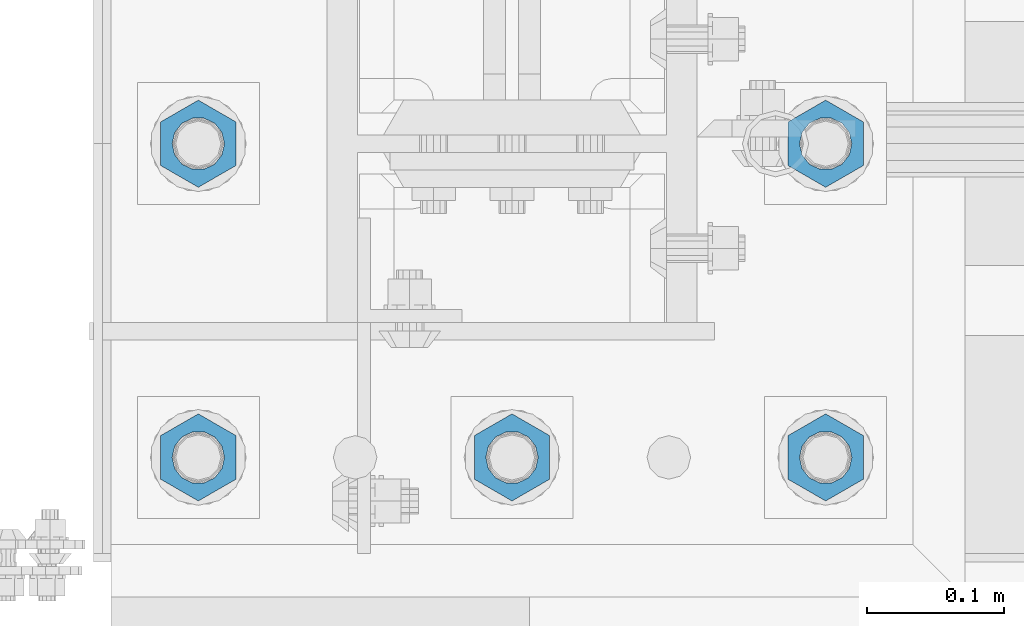
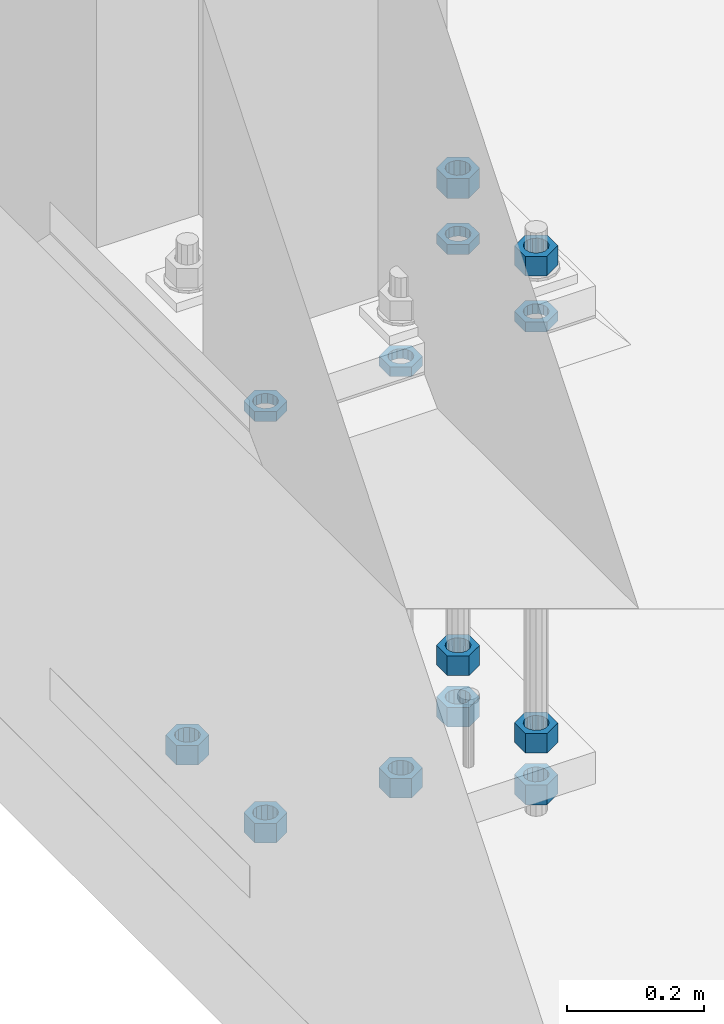
# One storey, part 1381 of 1876: 13 beams, 1 element without a shape of its own.
"""IFC2X3 building model written with IfcOpenShell, lengths in millimetres."""

from ifc_helpers import new_model, si_unit, frame, origin_with_axes, place, context, subcontext, project, spatial, faceted_brep, material, type_object, element, aggregate, save


model = new_model("IFC2X3")

# Units and contexts
model_context = context("Model", 3, precision=1e-05, world=origin_with_axes())
body_context = subcontext(model_context, "Body", "Model", "MODEL_VIEW")
ifc_project = project(units=[si_unit("LENGTHUNIT", "METRE", prefix="MILLI"), si_unit("AREAUNIT", "SQUARE_METRE"), si_unit("VOLUMEUNIT", "CUBIC_METRE"), si_unit("MASSUNIT", "GRAM", prefix="KILO"), si_unit("TIMEUNIT", "SECOND"), si_unit("PLANEANGLEUNIT", "RADIAN"), si_unit("SOLIDANGLEUNIT", "STERADIAN"), si_unit("THERMODYNAMICTEMPERATUREUNIT", "DEGREE_CELSIUS"), si_unit("LUMINOUSINTENSITYUNIT", "LUMEN")], contexts=[model_context])

# Site, building, storey
site_placement = place(None, origin_with_axes())
site = spatial("IfcSite", under=ifc_project, at=site_placement, CompositionType="ELEMENT")
building_placement = place(site_placement, origin_with_axes())
building = spatial("IfcBuilding", under=site, at=building_placement, Name="Undefined", CompositionType="ELEMENT")
storey_placement = place(building_placement, origin_with_axes())
storey = spatial("IfcBuildingStorey", under=building, at=storey_placement, Name="Undefined", CompositionType="ELEMENT", Elevation=0.0)

# Assembly, beams
assembly_placement = place(storey_placement, origin_with_axes())
assembly = element("IfcElementAssembly", 1, at=assembly_placement, inside=storey, Name="TEMPLATE", AssemblyPlace="NOTDEFINED", PredefinedType="RIGID_FRAME")
ifc_material = material(Name="STEEL/A563")
beam_type_1 = type_object("IfcBeamType", Name="1-3/8_DIA. HALF_NUT", PredefinedType="NOTDEFINED")
beam_1_placement = place(assembly_placement, frame((-228.6, -7340.6, 33.3375), z_axis=(1.0, 0.0, 0.0), x_axis=(0.0, 0.0, -1.0)))
beam_1 = element("IfcBeam", 2, at=beam_1_placement, type_object=beam_type_1, material=ifc_material, Name="NUT", ObjectType="1-3/8_DIA. HALF_NUT", context=body_context, shape_type="Brep", body=[
    faceted_brep([(0.0, -31.75, 0.0), (0.0, -15.8800001144409, -27.5), (17.4625, -15.8800001144409, -27.5), (17.4625, -31.75, 0.0), (0.0, 15.8800001144409, -27.5), (17.4625, 15.8800001144409, -27.5), (0.0, 31.75, 0.0), (17.4625, 31.75, 0.0), (0.0, 15.8800001144409, 27.5), (17.4625, 15.8800001144409, 27.5), (0.0, -15.8800001144409, 27.5), (17.4625, -15.8800001144409, 27.5), (0.0, 0.0, 19.0499999999993), (0.0, 8.2654848991624, 17.1634562461559), (17.4625, 8.2654848991624, 17.1634562461559), (17.4625, 0.0, 19.0499992370605), (0.0, 14.8938891445259, 11.8774802497237), (17.4625, 14.8938891445259, 11.8774802497237), (0.0, 18.5723759832526, 4.2390236220981), (17.4625, 18.5723759832526, 4.2390236220981), (0.0, 18.5723759832526, -4.2390236220981), (17.4625, 18.5723759832526, -4.2390236220981), (0.0, 14.8938891445259, -11.8774802497237), (17.4625, 14.8938891445259, -11.8774802497237), (0.0, 8.2654848991624, -17.1634562461568), (17.4625, 8.2654848991624, -17.1634562461568), (0.0, 0.0, -19.05), (17.4625, 0.0, -19.0499992370605), (0.0, -8.2654848991624, -17.1634562461559), (17.4625, -8.2654848991624, -17.1634562461559), (0.0, -14.8938891445259, -11.8774802497237), (17.4625, -14.8938891445259, -11.8774802497237), (0.0, -18.5723759832526, -4.2390236220981), (17.4625, -18.5723759832526, -4.2390236220981), (0.0, -18.5723759832526, 4.2390236220981), (17.4625, -18.5723759832526, 4.2390236220981), (0.0, -14.8938891445259, 11.8774802497237), (17.4625, -14.8938891445259, 11.8774802497237), (0.0, -8.2654848991624, 17.1634562461568), (17.4625, -8.2654848991624, 17.1634562461568)], [[[0, 1, 2, 3]], [[1, 4, 5, 2]], [[4, 6, 7, 5]], [[6, 8, 9, 7]], [[8, 10, 11, 9]], [[10, 0, 3, 11]], [[12, 13, 14, 15]], [[13, 16, 17, 14]], [[16, 18, 19, 17]], [[18, 20, 21, 19]], [[20, 22, 23, 21]], [[22, 24, 25, 23]], [[24, 26, 27, 25]], [[26, 28, 29, 27]], [[28, 30, 31, 29]], [[30, 32, 33, 31]], [[32, 34, 35, 33]], [[34, 36, 37, 35]], [[36, 38, 39, 37]], [[38, 12, 15, 39]], [[5, 7, 9, 11, 3, 2], [17, 19, 21, 23, 25, 27, 29, 31, 33, 35, 37, 39, 15, 14]], [[10, 8, 6, 4, 1, 0], [38, 36, 34, 32, 30, 28, 26, 24, 22, 20, 18, 16, 13, 12]]]),
])
beam_2_placement = place(assembly_placement, frame((228.6, -7112.0, 33.3375), z_axis=(1.0, 0.0, 0.0), x_axis=(0.0, 0.0, -1.0)))
beam_2 = element("IfcBeam", 3, at=beam_2_placement, type_object=beam_type_1, material=ifc_material, Name="NUT", ObjectType="1-3/8_DIA. HALF_NUT", context=body_context, shape_type="Brep", body=[
    faceted_brep([(0.0, -31.75, 0.0), (0.0, -15.8800001144409, -27.5), (17.4625, -15.8800001144409, -27.5), (17.4625, -31.75, 0.0), (0.0, 15.8800001144409, -27.5), (17.4625, 15.8800001144409, -27.5), (0.0, 31.75, 0.0), (17.4625, 31.75, 0.0), (0.0, 15.8800001144409, 27.5), (17.4625, 15.8800001144409, 27.5), (0.0, -15.8800001144409, 27.5), (17.4625, -15.8800001144409, 27.5), (0.0, 0.0, 19.0499999999993), (0.0, 8.2654848991624, 17.1634562461559), (17.4625, 8.2654848991624, 17.1634562461559), (17.4625, 0.0, 19.0499992370605), (0.0, 14.8938891445259, 11.8774802497237), (17.4625, 14.8938891445259, 11.8774802497237), (0.0, 18.5723759832526, 4.2390236220981), (17.4625, 18.5723759832526, 4.2390236220981), (0.0, 18.5723759832526, -4.2390236220981), (17.4625, 18.5723759832526, -4.2390236220981), (0.0, 14.8938891445259, -11.8774802497237), (17.4625, 14.8938891445259, -11.8774802497237), (0.0, 8.2654848991624, -17.1634562461568), (17.4625, 8.2654848991624, -17.1634562461568), (0.0, 0.0, -19.05), (17.4625, 0.0, -19.0499992370605), (0.0, -8.2654848991624, -17.1634562461559), (17.4625, -8.2654848991624, -17.1634562461559), (0.0, -14.8938891445259, -11.8774802497237), (17.4625, -14.8938891445259, -11.8774802497237), (0.0, -18.5723759832526, -4.2390236220981), (17.4625, -18.5723759832526, -4.2390236220981), (0.0, -18.5723759832526, 4.2390236220981), (17.4625, -18.5723759832526, 4.2390236220981), (0.0, -14.8938891445259, 11.8774802497237), (17.4625, -14.8938891445259, 11.8774802497237), (0.0, -8.2654848991624, 17.1634562461568), (17.4625, -8.2654848991624, 17.1634562461568)], [[[0, 1, 2, 3]], [[1, 4, 5, 2]], [[4, 6, 7, 5]], [[6, 8, 9, 7]], [[8, 10, 11, 9]], [[10, 0, 3, 11]], [[12, 13, 14, 15]], [[13, 16, 17, 14]], [[16, 18, 19, 17]], [[18, 20, 21, 19]], [[20, 22, 23, 21]], [[22, 24, 25, 23]], [[24, 26, 27, 25]], [[26, 28, 29, 27]], [[28, 30, 31, 29]], [[30, 32, 33, 31]], [[32, 34, 35, 33]], [[34, 36, 37, 35]], [[36, 38, 39, 37]], [[38, 12, 15, 39]], [[5, 7, 9, 11, 3, 2], [17, 19, 21, 23, 25, 27, 29, 31, 33, 35, 37, 39, 15, 14]], [[10, 8, 6, 4, 1, 0], [38, 36, 34, 32, 30, 28, 26, 24, 22, 20, 18, 16, 13, 12]]]),
])
beam_3_placement = place(assembly_placement, frame((228.6, -7340.6, 33.3375), z_axis=(1.0, 0.0, 0.0), x_axis=(0.0, 0.0, -1.0)))
beam_3 = element("IfcBeam", 4, at=beam_3_placement, type_object=beam_type_1, material=ifc_material, Name="NUT", ObjectType="1-3/8_DIA. HALF_NUT", context=body_context, shape_type="Brep", body=[
    faceted_brep([(0.0, -31.75, 0.0), (0.0, -15.8800001144409, -27.5), (17.4625, -15.8800001144409, -27.5), (17.4625, -31.75, 0.0), (0.0, 15.8800001144409, -27.5), (17.4625, 15.8800001144409, -27.5), (0.0, 31.75, 0.0), (17.4625, 31.75, 0.0), (0.0, 15.8800001144409, 27.5), (17.4625, 15.8800001144409, 27.5), (0.0, -15.8800001144409, 27.5), (17.4625, -15.8800001144409, 27.5), (0.0, 0.0, 19.0499999999993), (0.0, 8.2654848991624, 17.1634562461559), (17.4625, 8.2654848991624, 17.1634562461559), (17.4625, 0.0, 19.0499992370605), (0.0, 14.8938891445259, 11.8774802497237), (17.4625, 14.8938891445259, 11.8774802497237), (0.0, 18.5723759832526, 4.2390236220981), (17.4625, 18.5723759832526, 4.2390236220981), (0.0, 18.5723759832526, -4.2390236220981), (17.4625, 18.5723759832526, -4.2390236220981), (0.0, 14.8938891445259, -11.8774802497237), (17.4625, 14.8938891445259, -11.8774802497237), (0.0, 8.2654848991624, -17.1634562461568), (17.4625, 8.2654848991624, -17.1634562461568), (0.0, 0.0, -19.05), (17.4625, 0.0, -19.0499992370605), (0.0, -8.2654848991624, -17.1634562461559), (17.4625, -8.2654848991624, -17.1634562461559), (0.0, -14.8938891445259, -11.8774802497237), (17.4625, -14.8938891445259, -11.8774802497237), (0.0, -18.5723759832526, -4.2390236220981), (17.4625, -18.5723759832526, -4.2390236220981), (0.0, -18.5723759832526, 4.2390236220981), (17.4625, -18.5723759832526, 4.2390236220981), (0.0, -14.8938891445259, 11.8774802497237), (17.4625, -14.8938891445259, 11.8774802497237), (0.0, -8.2654848991624, 17.1634562461568), (17.4625, -8.2654848991624, 17.1634562461568)], [[[0, 1, 2, 3]], [[1, 4, 5, 2]], [[4, 6, 7, 5]], [[6, 8, 9, 7]], [[8, 10, 11, 9]], [[10, 0, 3, 11]], [[12, 13, 14, 15]], [[13, 16, 17, 14]], [[16, 18, 19, 17]], [[18, 20, 21, 19]], [[20, 22, 23, 21]], [[22, 24, 25, 23]], [[24, 26, 27, 25]], [[26, 28, 29, 27]], [[28, 30, 31, 29]], [[30, 32, 33, 31]], [[32, 34, 35, 33]], [[34, 36, 37, 35]], [[36, 38, 39, 37]], [[38, 12, 15, 39]], [[5, 7, 9, 11, 3, 2], [17, 19, 21, 23, 25, 27, 29, 31, 33, 35, 37, 39, 15, 14]], [[10, 8, 6, 4, 1, 0], [38, 36, 34, 32, 30, 28, 26, 24, 22, 20, 18, 16, 13, 12]]]),
])
beam_4_placement = place(assembly_placement, frame((0.0, -7340.6, 33.3375), z_axis=(1.0, 0.0, 0.0), x_axis=(0.0, 0.0, -1.0)))
beam_4 = element("IfcBeam", 5, at=beam_4_placement, type_object=beam_type_1, material=ifc_material, Name="NUT", ObjectType="1-3/8_DIA. HALF_NUT", context=body_context, shape_type="Brep", body=[
    faceted_brep([(0.0, -31.75, 0.0), (0.0, -15.8800001144409, -27.5), (17.4625, -15.8800001144409, -27.5), (17.4625, -31.75, 0.0), (0.0, 15.8800001144409, -27.5), (17.4625, 15.8800001144409, -27.5), (0.0, 31.75, 0.0), (17.4625, 31.75, 0.0), (0.0, 15.8800001144409, 27.5), (17.4625, 15.8800001144409, 27.5), (0.0, -15.8800001144409, 27.5), (17.4625, -15.8800001144409, 27.5), (0.0, 0.0, 19.0499999999993), (0.0, 8.2654848991624, 17.1634562461559), (17.4625, 8.2654848991624, 17.1634562461559), (17.4625, 0.0, 19.0499992370605), (0.0, 14.8938891445259, 11.8774802497237), (17.4625, 14.8938891445259, 11.8774802497237), (0.0, 18.5723759832526, 4.2390236220981), (17.4625, 18.5723759832526, 4.2390236220981), (0.0, 18.5723759832526, -4.2390236220981), (17.4625, 18.5723759832526, -4.2390236220981), (0.0, 14.8938891445259, -11.8774802497237), (17.4625, 14.8938891445259, -11.8774802497237), (0.0, 8.2654848991624, -17.1634562461568), (17.4625, 8.2654848991624, -17.1634562461568), (0.0, 0.0, -19.05), (17.4625, 0.0, -19.0499992370605), (0.0, -8.2654848991624, -17.1634562461559), (17.4625, -8.2654848991624, -17.1634562461559), (0.0, -14.8938891445259, -11.8774802497237), (17.4625, -14.8938891445259, -11.8774802497237), (0.0, -18.5723759832526, -4.2390236220981), (17.4625, -18.5723759832526, -4.2390236220981), (0.0, -18.5723759832526, 4.2390236220981), (17.4625, -18.5723759832526, 4.2390236220981), (0.0, -14.8938891445259, 11.8774802497237), (17.4625, -14.8938891445259, 11.8774802497237), (0.0, -8.2654848991624, 17.1634562461568), (17.4625, -8.2654848991624, 17.1634562461568)], [[[0, 1, 2, 3]], [[1, 4, 5, 2]], [[4, 6, 7, 5]], [[6, 8, 9, 7]], [[8, 10, 11, 9]], [[10, 0, 3, 11]], [[12, 13, 14, 15]], [[13, 16, 17, 14]], [[16, 18, 19, 17]], [[18, 20, 21, 19]], [[20, 22, 23, 21]], [[22, 24, 25, 23]], [[24, 26, 27, 25]], [[26, 28, 29, 27]], [[28, 30, 31, 29]], [[30, 32, 33, 31]], [[32, 34, 35, 33]], [[34, 36, 37, 35]], [[36, 38, 39, 37]], [[38, 12, 15, 39]], [[5, 7, 9, 11, 3, 2], [17, 19, 21, 23, 25, 27, 29, 31, 33, 35, 37, 39, 15, 14]], [[10, 8, 6, 4, 1, 0], [38, 36, 34, 32, 30, 28, 26, 24, 22, 20, 18, 16, 13, 12]]]),
])
beam_type_2 = type_object("IfcBeamType", Name="1-3/8_HEAVY_HEX_NUT", PredefinedType="NOTDEFINED")
beam_5_placement = place(assembly_placement, frame((228.600012207031, -7340.6, -701.674998474121), z_axis=(1.0, 0.0, 0.0), x_axis=(0.0, 0.0, -1.0)))
beam_5 = element("IfcBeam", 6, at=beam_5_placement, type_object=beam_type_2, material=ifc_material, Name="NUT", ObjectType="1-3/8_HEAVY_HEX_NUT", context=body_context, shape_type="Brep", body=[
    faceted_brep([(0.0, -31.75, 0.0), (0.0, -15.8800001144409, -27.5), (34.925, -15.8800001144409, -27.5), (34.925, -31.75, 0.0), (0.0, 15.8800001144409, -27.5), (34.925, 15.8800001144409, -27.5), (0.0, 31.75, 0.0), (34.925, 31.75, 0.0), (0.0, 15.8800001144409, 27.5), (34.925, 15.8800001144409, 27.5), (0.0, -15.8800001144409, 27.5), (34.925, -15.8800001144409, 27.5), (0.0, 0.0, 19.0499999999993), (0.0, 8.2654848991624, 17.1634562461559), (34.925, 8.26548489916252, 17.163456246155), (34.925, 0.0, 19.0499992370605), (0.0, 14.8938891445259, 11.8774802497237), (34.925, 14.8938891445259, 11.8774802497246), (0.0, 18.5723759832526, 4.2390236220981), (34.925, 18.5723759832528, 4.23902362209628), (0.0, 18.5723759832526, -4.2390236220981), (34.925, 18.5723759832528, -4.23902362209628), (0.0, 14.8938891445259, -11.8774802497237), (34.925, 14.8938891445259, -11.8774802497246), (0.0, 8.2654848991624, -17.1634562461568), (34.925, 8.26548489916252, -17.163456246155), (0.0, 0.0, -19.05), (34.925, 0.0, -19.0499992370605), (0.0, -8.2654848991624, -17.1634562461559), (34.925, -8.26548489916252, -17.163456246155), (0.0, -14.8938891445259, -11.8774802497237), (34.925, -14.8938891445259, -11.8774802497246), (0.0, -18.5723759832526, -4.2390236220981), (34.925, -18.5723759832528, -4.23902362209628), (0.0, -18.5723759832526, 4.2390236220981), (34.925, -18.5723759832528, 4.23902362209628), (0.0, -14.8938891445259, 11.8774802497237), (34.925, -14.8938891445259, 11.8774802497246), (0.0, -8.2654848991624, 17.1634562461568), (34.925, -8.26548489916252, 17.163456246155)], [[[0, 1, 2, 3]], [[1, 4, 5, 2]], [[4, 6, 7, 5]], [[6, 8, 9, 7]], [[8, 10, 11, 9]], [[10, 0, 3, 11]], [[12, 13, 14, 15]], [[13, 16, 17, 14]], [[16, 18, 19, 17]], [[18, 20, 21, 19]], [[20, 22, 23, 21]], [[22, 24, 25, 23]], [[24, 26, 27, 25]], [[26, 28, 29, 27]], [[28, 30, 31, 29]], [[30, 32, 33, 31]], [[32, 34, 35, 33]], [[34, 36, 37, 35]], [[36, 38, 39, 37]], [[38, 12, 15, 39]], [[5, 7, 9, 11, 3, 2], [17, 19, 21, 23, 25, 27, 29, 31, 33, 35, 37, 39, 15, 14]], [[10, 8, 6, 4, 1, 0], [38, 36, 34, 32, 30, 28, 26, 24, 22, 20, 18, 16, 13, 12]]]),
])
beam_6_placement = place(assembly_placement, frame((228.600012207031, -7112.0, -701.674998474121), z_axis=(1.0, 0.0, 0.0), x_axis=(0.0, 0.0, -1.0)))
beam_6 = element("IfcBeam", 7, at=beam_6_placement, type_object=beam_type_2, material=ifc_material, Name="NUT", ObjectType="1-3/8_HEAVY_HEX_NUT", context=body_context, shape_type="Brep", body=[
    faceted_brep([(0.0, -31.75, 0.0), (0.0, -15.8800001144409, -27.5), (34.925, -15.8800001144409, -27.5), (34.925, -31.75, 0.0), (0.0, 15.8800001144409, -27.5), (34.925, 15.8800001144409, -27.5), (0.0, 31.75, 0.0), (34.925, 31.75, 0.0), (0.0, 15.8800001144409, 27.5), (34.925, 15.8800001144409, 27.5), (0.0, -15.8800001144409, 27.5), (34.925, -15.8800001144409, 27.5), (0.0, 0.0, 19.0499999999993), (0.0, 8.2654848991624, 17.1634562461559), (34.925, 8.26548489916252, 17.163456246155), (34.925, 0.0, 19.0499992370605), (0.0, 14.8938891445259, 11.8774802497237), (34.925, 14.8938891445259, 11.8774802497246), (0.0, 18.5723759832526, 4.2390236220981), (34.925, 18.5723759832528, 4.23902362209628), (0.0, 18.5723759832526, -4.2390236220981), (34.925, 18.5723759832528, -4.23902362209628), (0.0, 14.8938891445259, -11.8774802497237), (34.925, 14.8938891445259, -11.8774802497246), (0.0, 8.2654848991624, -17.1634562461568), (34.925, 8.26548489916252, -17.163456246155), (0.0, 0.0, -19.05), (34.925, 0.0, -19.0499992370605), (0.0, -8.2654848991624, -17.1634562461559), (34.925, -8.26548489916252, -17.163456246155), (0.0, -14.8938891445259, -11.8774802497237), (34.925, -14.8938891445259, -11.8774802497246), (0.0, -18.5723759832526, -4.2390236220981), (34.925, -18.5723759832528, -4.23902362209628), (0.0, -18.5723759832526, 4.2390236220981), (34.925, -18.5723759832528, 4.23902362209628), (0.0, -14.8938891445259, 11.8774802497237), (34.925, -14.8938891445259, 11.8774802497246), (0.0, -8.2654848991624, 17.1634562461568), (34.925, -8.26548489916252, 17.163456246155)], [[[0, 1, 2, 3]], [[1, 4, 5, 2]], [[4, 6, 7, 5]], [[6, 8, 9, 7]], [[8, 10, 11, 9]], [[10, 0, 3, 11]], [[12, 13, 14, 15]], [[13, 16, 17, 14]], [[16, 18, 19, 17]], [[18, 20, 21, 19]], [[20, 22, 23, 21]], [[22, 24, 25, 23]], [[24, 26, 27, 25]], [[26, 28, 29, 27]], [[28, 30, 31, 29]], [[30, 32, 33, 31]], [[32, 34, 35, 33]], [[34, 36, 37, 35]], [[36, 38, 39, 37]], [[38, 12, 15, 39]], [[5, 7, 9, 11, 3, 2], [17, 19, 21, 23, 25, 27, 29, 31, 33, 35, 37, 39, 15, 14]], [[10, 8, 6, 4, 1, 0], [38, 36, 34, 32, 30, 28, 26, 24, 22, 20, 18, 16, 13, 12]]]),
])
beam_7_placement = place(assembly_placement, frame((1.22070313182121e-05, -7340.6, -701.674998474121), z_axis=(1.0, 0.0, 0.0), x_axis=(0.0, 0.0, -1.0)))
beam_7 = element("IfcBeam", 8, at=beam_7_placement, type_object=beam_type_2, material=ifc_material, Name="NUT", ObjectType="1-3/8_HEAVY_HEX_NUT", context=body_context, shape_type="Brep", body=[
    faceted_brep([(0.0, -31.75, 0.0), (0.0, -15.8800001144409, -27.5), (34.925, -15.8800001144409, -27.5), (34.925, -31.75, 0.0), (0.0, 15.8800001144409, -27.5), (34.925, 15.8800001144409, -27.5), (0.0, 31.75, 0.0), (34.925, 31.75, 0.0), (0.0, 15.8800001144409, 27.5), (34.925, 15.8800001144409, 27.5), (0.0, -15.8800001144409, 27.5), (34.925, -15.8800001144409, 27.5), (0.0, 0.0, 19.0499999999993), (0.0, 8.2654848991624, 17.1634562461559), (34.925, 8.26548489916252, 17.163456246155), (34.925, 0.0, 19.0499992370605), (0.0, 14.8938891445259, 11.8774802497237), (34.925, 14.8938891445259, 11.8774802497246), (0.0, 18.5723759832526, 4.2390236220981), (34.925, 18.5723759832528, 4.23902362209628), (0.0, 18.5723759832526, -4.2390236220981), (34.925, 18.5723759832528, -4.23902362209628), (0.0, 14.8938891445259, -11.8774802497237), (34.925, 14.8938891445259, -11.8774802497246), (0.0, 8.2654848991624, -17.1634562461568), (34.925, 8.26548489916252, -17.163456246155), (0.0, 0.0, -19.05), (34.925, 0.0, -19.0499992370605), (0.0, -8.2654848991624, -17.1634562461559), (34.925, -8.26548489916252, -17.163456246155), (0.0, -14.8938891445259, -11.8774802497237), (34.925, -14.8938891445259, -11.8774802497246), (0.0, -18.5723759832526, -4.2390236220981), (34.925, -18.5723759832528, -4.23902362209628), (0.0, -18.5723759832526, 4.2390236220981), (34.925, -18.5723759832528, 4.23902362209628), (0.0, -14.8938891445259, 11.8774802497237), (34.925, -14.8938891445259, 11.8774802497246), (0.0, -8.2654848991624, 17.1634562461568), (34.925, -8.26548489916252, 17.163456246155)], [[[0, 1, 2, 3]], [[1, 4, 5, 2]], [[4, 6, 7, 5]], [[6, 8, 9, 7]], [[8, 10, 11, 9]], [[10, 0, 3, 11]], [[12, 13, 14, 15]], [[13, 16, 17, 14]], [[16, 18, 19, 17]], [[18, 20, 21, 19]], [[20, 22, 23, 21]], [[22, 24, 25, 23]], [[24, 26, 27, 25]], [[26, 28, 29, 27]], [[28, 30, 31, 29]], [[30, 32, 33, 31]], [[32, 34, 35, 33]], [[34, 36, 37, 35]], [[36, 38, 39, 37]], [[38, 12, 15, 39]], [[5, 7, 9, 11, 3, 2], [17, 19, 21, 23, 25, 27, 29, 31, 33, 35, 37, 39, 15, 14]], [[10, 8, 6, 4, 1, 0], [38, 36, 34, 32, 30, 28, 26, 24, 22, 20, 18, 16, 13, 12]]]),
])
beam_8_placement = place(assembly_placement, frame((-228.599987792969, -7340.6, -701.674998474121), z_axis=(1.0, 0.0, 0.0), x_axis=(0.0, 0.0, -1.0)))
beam_8 = element("IfcBeam", 9, at=beam_8_placement, type_object=beam_type_2, material=ifc_material, Name="NUT", ObjectType="1-3/8_HEAVY_HEX_NUT", context=body_context, shape_type="Brep", body=[
    faceted_brep([(0.0, -31.75, 0.0), (0.0, -15.8800001144409, -27.5), (34.925, -15.8800001144409, -27.5), (34.925, -31.75, 0.0), (0.0, 15.8800001144409, -27.5), (34.925, 15.8800001144409, -27.5), (0.0, 31.75, 0.0), (34.925, 31.75, 0.0), (0.0, 15.8800001144409, 27.5), (34.925, 15.8800001144409, 27.5), (0.0, -15.8800001144409, 27.5), (34.925, -15.8800001144409, 27.5), (0.0, 0.0, 19.0499999999993), (0.0, 8.2654848991624, 17.1634562461559), (34.925, 8.26548489916252, 17.163456246155), (34.925, 0.0, 19.0499992370605), (0.0, 14.8938891445259, 11.8774802497237), (34.925, 14.8938891445259, 11.8774802497246), (0.0, 18.5723759832526, 4.2390236220981), (34.925, 18.5723759832528, 4.23902362209628), (0.0, 18.5723759832526, -4.2390236220981), (34.925, 18.5723759832528, -4.23902362209628), (0.0, 14.8938891445259, -11.8774802497237), (34.925, 14.8938891445259, -11.8774802497246), (0.0, 8.2654848991624, -17.1634562461568), (34.925, 8.26548489916252, -17.163456246155), (0.0, 0.0, -19.05), (34.925, 0.0, -19.0499992370605), (0.0, -8.2654848991624, -17.1634562461559), (34.925, -8.26548489916252, -17.163456246155), (0.0, -14.8938891445259, -11.8774802497237), (34.925, -14.8938891445259, -11.8774802497246), (0.0, -18.5723759832526, -4.2390236220981), (34.925, -18.5723759832528, -4.23902362209628), (0.0, -18.5723759832526, 4.2390236220981), (34.925, -18.5723759832528, 4.23902362209628), (0.0, -14.8938891445259, 11.8774802497237), (34.925, -14.8938891445259, 11.8774802497246), (0.0, -8.2654848991624, 17.1634562461568), (34.925, -8.26548489916252, 17.163456246155)], [[[0, 1, 2, 3]], [[1, 4, 5, 2]], [[4, 6, 7, 5]], [[6, 8, 9, 7]], [[8, 10, 11, 9]], [[10, 0, 3, 11]], [[12, 13, 14, 15]], [[13, 16, 17, 14]], [[16, 18, 19, 17]], [[18, 20, 21, 19]], [[20, 22, 23, 21]], [[22, 24, 25, 23]], [[24, 26, 27, 25]], [[26, 28, 29, 27]], [[28, 30, 31, 29]], [[30, 32, 33, 31]], [[32, 34, 35, 33]], [[34, 36, 37, 35]], [[36, 38, 39, 37]], [[38, 12, 15, 39]], [[5, 7, 9, 11, 3, 2], [17, 19, 21, 23, 25, 27, 29, 31, 33, 35, 37, 39, 15, 14]], [[10, 8, 6, 4, 1, 0], [38, 36, 34, 32, 30, 28, 26, 24, 22, 20, 18, 16, 13, 12]]]),
])
beam_9_placement = place(assembly_placement, frame((-228.599987792969, -7112.0, -701.674998474121), z_axis=(1.0, 0.0, 0.0), x_axis=(0.0, 0.0, -1.0)))
beam_9 = element("IfcBeam", 10, at=beam_9_placement, type_object=beam_type_2, material=ifc_material, Name="NUT", ObjectType="1-3/8_HEAVY_HEX_NUT", context=body_context, shape_type="Brep", body=[
    faceted_brep([(0.0, -31.75, 0.0), (0.0, -15.8800001144409, -27.5), (34.925, -15.8800001144409, -27.5), (34.925, -31.75, 0.0), (0.0, 15.8800001144409, -27.5), (34.925, 15.8800001144409, -27.5), (0.0, 31.75, 0.0), (34.925, 31.75, 0.0), (0.0, 15.8800001144409, 27.5), (34.925, 15.8800001144409, 27.5), (0.0, -15.8800001144409, 27.5), (34.925, -15.8800001144409, 27.5), (0.0, 0.0, 19.0499999999993), (0.0, 8.2654848991624, 17.1634562461559), (34.925, 8.26548489916252, 17.163456246155), (34.925, 0.0, 19.0499992370605), (0.0, 14.8938891445259, 11.8774802497237), (34.925, 14.8938891445259, 11.8774802497246), (0.0, 18.5723759832526, 4.2390236220981), (34.925, 18.5723759832528, 4.23902362209628), (0.0, 18.5723759832526, -4.2390236220981), (34.925, 18.5723759832528, -4.23902362209628), (0.0, 14.8938891445259, -11.8774802497237), (34.925, 14.8938891445259, -11.8774802497246), (0.0, 8.2654848991624, -17.1634562461568), (34.925, 8.26548489916252, -17.163456246155), (0.0, 0.0, -19.05), (34.925, 0.0, -19.0499992370605), (0.0, -8.2654848991624, -17.1634562461559), (34.925, -8.26548489916252, -17.163456246155), (0.0, -14.8938891445259, -11.8774802497237), (34.925, -14.8938891445259, -11.8774802497246), (0.0, -18.5723759832526, -4.2390236220981), (34.925, -18.5723759832528, -4.23902362209628), (0.0, -18.5723759832526, 4.2390236220981), (34.925, -18.5723759832528, 4.23902362209628), (0.0, -14.8938891445259, 11.8774802497237), (34.925, -14.8938891445259, 11.8774802497246), (0.0, -8.2654848991624, 17.1634562461568), (34.925, -8.26548489916252, 17.163456246155)], [[[0, 1, 2, 3]], [[1, 4, 5, 2]], [[4, 6, 7, 5]], [[6, 8, 9, 7]], [[8, 10, 11, 9]], [[10, 0, 3, 11]], [[12, 13, 14, 15]], [[13, 16, 17, 14]], [[16, 18, 19, 17]], [[18, 20, 21, 19]], [[20, 22, 23, 21]], [[22, 24, 25, 23]], [[24, 26, 27, 25]], [[26, 28, 29, 27]], [[28, 30, 31, 29]], [[30, 32, 33, 31]], [[32, 34, 35, 33]], [[34, 36, 37, 35]], [[36, 38, 39, 37]], [[38, 12, 15, 39]], [[5, 7, 9, 11, 3, 2], [17, 19, 21, 23, 25, 27, 29, 31, 33, 35, 37, 39, 15, 14]], [[10, 8, 6, 4, 1, 0], [38, 36, 34, 32, 30, 28, 26, 24, 22, 20, 18, 16, 13, 12]]]),
])
beam_10_placement = place(assembly_placement, frame((228.6, -7340.6, 150.8125), z_axis=(1.0, 0.0, 0.0), x_axis=(0.0, 0.0, -1.0)))
beam_10 = element("IfcBeam", 11, at=beam_10_placement, type_object=beam_type_2, material=ifc_material, Name="NUT", ObjectType="1-3/8_HEAVY_HEX_NUT", context=body_context, shape_type="Brep", body=[
    faceted_brep([(0.0, -31.75, 0.0), (0.0, -15.8800001144409, -27.5), (34.925, -15.8800001144409, -27.5), (34.925, -31.75, 0.0), (0.0, 15.8800001144409, -27.5), (34.925, 15.8800001144409, -27.5), (0.0, 31.75, 0.0), (34.925, 31.75, 0.0), (0.0, 15.8800001144409, 27.5), (34.925, 15.8800001144409, 27.5), (0.0, -15.8800001144409, 27.5), (34.925, -15.8800001144409, 27.5), (0.0, 0.0, 19.0499999999993), (0.0, 8.2654848991624, 17.1634562461559), (34.925, 8.26548489916252, 17.163456246155), (34.925, 0.0, 19.0499992370605), (0.0, 14.8938891445259, 11.8774802497237), (34.925, 14.8938891445259, 11.8774802497246), (0.0, 18.5723759832526, 4.2390236220981), (34.925, 18.5723759832528, 4.23902362209628), (0.0, 18.5723759832526, -4.2390236220981), (34.925, 18.5723759832528, -4.23902362209628), (0.0, 14.8938891445259, -11.8774802497237), (34.925, 14.8938891445259, -11.8774802497246), (0.0, 8.2654848991624, -17.1634562461568), (34.925, 8.26548489916252, -17.163456246155), (0.0, 0.0, -19.05), (34.925, 0.0, -19.0499992370605), (0.0, -8.2654848991624, -17.1634562461559), (34.925, -8.26548489916252, -17.163456246155), (0.0, -14.8938891445259, -11.8774802497237), (34.925, -14.8938891445259, -11.8774802497246), (0.0, -18.5723759832526, -4.2390236220981), (34.925, -18.5723759832528, -4.23902362209628), (0.0, -18.5723759832526, 4.2390236220981), (34.925, -18.5723759832528, 4.23902362209628), (0.0, -14.8938891445259, 11.8774802497237), (34.925, -14.8938891445259, 11.8774802497246), (0.0, -8.2654848991624, 17.1634562461568), (34.925, -8.26548489916252, 17.163456246155)], [[[0, 1, 2, 3]], [[1, 4, 5, 2]], [[4, 6, 7, 5]], [[6, 8, 9, 7]], [[8, 10, 11, 9]], [[10, 0, 3, 11]], [[12, 13, 14, 15]], [[13, 16, 17, 14]], [[16, 18, 19, 17]], [[18, 20, 21, 19]], [[20, 22, 23, 21]], [[22, 24, 25, 23]], [[24, 26, 27, 25]], [[26, 28, 29, 27]], [[28, 30, 31, 29]], [[30, 32, 33, 31]], [[32, 34, 35, 33]], [[34, 36, 37, 35]], [[36, 38, 39, 37]], [[38, 12, 15, 39]], [[5, 7, 9, 11, 3, 2], [17, 19, 21, 23, 25, 27, 29, 31, 33, 35, 37, 39, 15, 14]], [[10, 8, 6, 4, 1, 0], [38, 36, 34, 32, 30, 28, 26, 24, 22, 20, 18, 16, 13, 12]]]),
])
beam_11_placement = place(assembly_placement, frame((228.6, -7340.6, -793.75), z_axis=(1.0, 0.0, 0.0), x_axis=(0.0, 0.0, -1.0)))
beam_11 = element("IfcBeam", 12, at=beam_11_placement, type_object=beam_type_2, material=ifc_material, Name="NUT", ObjectType="1-3/8_HEAVY_HEX_NUT", context=body_context, shape_type="Brep", body=[
    faceted_brep([(0.0, -31.75, 0.0), (0.0, -15.8800001144409, -27.5), (34.925, -15.8800001144409, -27.5), (34.925, -31.75, 0.0), (0.0, 15.8800001144409, -27.5), (34.925, 15.8800001144409, -27.5), (0.0, 31.75, 0.0), (34.925, 31.75, 0.0), (0.0, 15.8800001144409, 27.5), (34.925, 15.8800001144409, 27.5), (0.0, -15.8800001144409, 27.5), (34.925, -15.8800001144409, 27.5), (0.0, 0.0, 19.0499999999993), (0.0, 8.2654848991624, 17.1634562461559), (34.925, 8.26548489916252, 17.163456246155), (34.925, 0.0, 19.0499992370605), (0.0, 14.8938891445259, 11.8774802497237), (34.925, 14.8938891445259, 11.8774802497246), (0.0, 18.5723759832526, 4.2390236220981), (34.925, 18.5723759832528, 4.23902362209628), (0.0, 18.5723759832526, -4.2390236220981), (34.925, 18.5723759832528, -4.23902362209628), (0.0, 14.8938891445259, -11.8774802497237), (34.925, 14.8938891445259, -11.8774802497246), (0.0, 8.2654848991624, -17.1634562461568), (34.925, 8.26548489916252, -17.163456246155), (0.0, 0.0, -19.05), (34.925, 0.0, -19.0499992370605), (0.0, -8.2654848991624, -17.1634562461559), (34.925, -8.26548489916252, -17.163456246155), (0.0, -14.8938891445259, -11.8774802497237), (34.925, -14.8938891445259, -11.8774802497246), (0.0, -18.5723759832526, -4.2390236220981), (34.925, -18.5723759832528, -4.23902362209628), (0.0, -18.5723759832526, 4.2390236220981), (34.925, -18.5723759832528, 4.23902362209628), (0.0, -14.8938891445259, 11.8774802497237), (34.925, -14.8938891445259, 11.8774802497246), (0.0, -8.2654848991624, 17.1634562461568), (34.925, -8.26548489916252, 17.163456246155)], [[[0, 1, 2, 3]], [[1, 4, 5, 2]], [[4, 6, 7, 5]], [[6, 8, 9, 7]], [[8, 10, 11, 9]], [[10, 0, 3, 11]], [[12, 13, 14, 15]], [[13, 16, 17, 14]], [[16, 18, 19, 17]], [[18, 20, 21, 19]], [[20, 22, 23, 21]], [[22, 24, 25, 23]], [[24, 26, 27, 25]], [[26, 28, 29, 27]], [[28, 30, 31, 29]], [[30, 32, 33, 31]], [[32, 34, 35, 33]], [[34, 36, 37, 35]], [[36, 38, 39, 37]], [[38, 12, 15, 39]], [[5, 7, 9, 11, 3, 2], [17, 19, 21, 23, 25, 27, 29, 31, 33, 35, 37, 39, 15, 14]], [[10, 8, 6, 4, 1, 0], [38, 36, 34, 32, 30, 28, 26, 24, 22, 20, 18, 16, 13, 12]]]),
])
beam_12_placement = place(assembly_placement, frame((228.6, -7112.0, 150.8125), z_axis=(1.0, 0.0, 0.0), x_axis=(0.0, 0.0, -1.0)))
beam_12 = element("IfcBeam", 13, at=beam_12_placement, type_object=beam_type_2, material=ifc_material, Name="NUT", ObjectType="1-3/8_HEAVY_HEX_NUT", context=body_context, shape_type="Brep", body=[
    faceted_brep([(0.0, -31.75, 0.0), (0.0, -15.8800001144409, -27.5), (34.925, -15.8800001144409, -27.5), (34.925, -31.75, 0.0), (0.0, 15.8800001144409, -27.5), (34.925, 15.8800001144409, -27.5), (0.0, 31.75, 0.0), (34.925, 31.75, 0.0), (0.0, 15.8800001144409, 27.5), (34.925, 15.8800001144409, 27.5), (0.0, -15.8800001144409, 27.5), (34.925, -15.8800001144409, 27.5), (0.0, 0.0, 19.0499999999993), (0.0, 8.2654848991624, 17.1634562461559), (34.925, 8.26548489916252, 17.163456246155), (34.925, 0.0, 19.0499992370605), (0.0, 14.8938891445259, 11.8774802497237), (34.925, 14.8938891445259, 11.8774802497246), (0.0, 18.5723759832526, 4.2390236220981), (34.925, 18.5723759832528, 4.23902362209628), (0.0, 18.5723759832526, -4.2390236220981), (34.925, 18.5723759832528, -4.23902362209628), (0.0, 14.8938891445259, -11.8774802497237), (34.925, 14.8938891445259, -11.8774802497246), (0.0, 8.2654848991624, -17.1634562461568), (34.925, 8.26548489916252, -17.163456246155), (0.0, 0.0, -19.05), (34.925, 0.0, -19.0499992370605), (0.0, -8.2654848991624, -17.1634562461559), (34.925, -8.26548489916252, -17.163456246155), (0.0, -14.8938891445259, -11.8774802497237), (34.925, -14.8938891445259, -11.8774802497246), (0.0, -18.5723759832526, -4.2390236220981), (34.925, -18.5723759832528, -4.23902362209628), (0.0, -18.5723759832526, 4.2390236220981), (34.925, -18.5723759832528, 4.23902362209628), (0.0, -14.8938891445259, 11.8774802497237), (34.925, -14.8938891445259, 11.8774802497246), (0.0, -8.2654848991624, 17.1634562461568), (34.925, -8.26548489916252, 17.163456246155)], [[[0, 1, 2, 3]], [[1, 4, 5, 2]], [[4, 6, 7, 5]], [[6, 8, 9, 7]], [[8, 10, 11, 9]], [[10, 0, 3, 11]], [[12, 13, 14, 15]], [[13, 16, 17, 14]], [[16, 18, 19, 17]], [[18, 20, 21, 19]], [[20, 22, 23, 21]], [[22, 24, 25, 23]], [[24, 26, 27, 25]], [[26, 28, 29, 27]], [[28, 30, 31, 29]], [[30, 32, 33, 31]], [[32, 34, 35, 33]], [[34, 36, 37, 35]], [[36, 38, 39, 37]], [[38, 12, 15, 39]], [[5, 7, 9, 11, 3, 2], [17, 19, 21, 23, 25, 27, 29, 31, 33, 35, 37, 39, 15, 14]], [[10, 8, 6, 4, 1, 0], [38, 36, 34, 32, 30, 28, 26, 24, 22, 20, 18, 16, 13, 12]]]),
])
beam_13_placement = place(assembly_placement, frame((228.6, -7112.0, -793.75), z_axis=(1.0, 0.0, 0.0), x_axis=(0.0, 0.0, -1.0)))
beam_13 = element("IfcBeam", 14, at=beam_13_placement, type_object=beam_type_2, material=ifc_material, Name="NUT", ObjectType="1-3/8_HEAVY_HEX_NUT", context=body_context, shape_type="Brep", body=[
    faceted_brep([(0.0, -31.75, 0.0), (0.0, -15.8800001144409, -27.5), (34.925, -15.8800001144409, -27.5), (34.925, -31.75, 0.0), (0.0, 15.8800001144409, -27.5), (34.925, 15.8800001144409, -27.5), (0.0, 31.75, 0.0), (34.925, 31.75, 0.0), (0.0, 15.8800001144409, 27.5), (34.925, 15.8800001144409, 27.5), (0.0, -15.8800001144409, 27.5), (34.925, -15.8800001144409, 27.5), (0.0, 0.0, 19.0499999999993), (0.0, 8.2654848991624, 17.1634562461559), (34.925, 8.26548489916252, 17.163456246155), (34.925, 0.0, 19.0499992370605), (0.0, 14.8938891445259, 11.8774802497237), (34.925, 14.8938891445259, 11.8774802497246), (0.0, 18.5723759832526, 4.2390236220981), (34.925, 18.5723759832528, 4.23902362209628), (0.0, 18.5723759832526, -4.2390236220981), (34.925, 18.5723759832528, -4.23902362209628), (0.0, 14.8938891445259, -11.8774802497237), (34.925, 14.8938891445259, -11.8774802497246), (0.0, 8.2654848991624, -17.1634562461568), (34.925, 8.26548489916252, -17.163456246155), (0.0, 0.0, -19.05), (34.925, 0.0, -19.0499992370605), (0.0, -8.2654848991624, -17.1634562461559), (34.925, -8.26548489916252, -17.163456246155), (0.0, -14.8938891445259, -11.8774802497237), (34.925, -14.8938891445259, -11.8774802497246), (0.0, -18.5723759832526, -4.2390236220981), (34.925, -18.5723759832528, -4.23902362209628), (0.0, -18.5723759832526, 4.2390236220981), (34.925, -18.5723759832528, 4.23902362209628), (0.0, -14.8938891445259, 11.8774802497237), (34.925, -14.8938891445259, 11.8774802497246), (0.0, -8.2654848991624, 17.1634562461568), (34.925, -8.26548489916252, 17.163456246155)], [[[0, 1, 2, 3]], [[1, 4, 5, 2]], [[4, 6, 7, 5]], [[6, 8, 9, 7]], [[8, 10, 11, 9]], [[10, 0, 3, 11]], [[12, 13, 14, 15]], [[13, 16, 17, 14]], [[16, 18, 19, 17]], [[18, 20, 21, 19]], [[20, 22, 23, 21]], [[22, 24, 25, 23]], [[24, 26, 27, 25]], [[26, 28, 29, 27]], [[28, 30, 31, 29]], [[30, 32, 33, 31]], [[32, 34, 35, 33]], [[34, 36, 37, 35]], [[36, 38, 39, 37]], [[38, 12, 15, 39]], [[5, 7, 9, 11, 3, 2], [17, 19, 21, 23, 25, 27, 29, 31, 33, 35, 37, 39, 15, 14]], [[10, 8, 6, 4, 1, 0], [38, 36, 34, 32, 30, 28, 26, 24, 22, 20, 18, 16, 13, 12]]]),
])
aggregate(assembly, [beam_1, beam_2, beam_3, beam_4, beam_5, beam_6, beam_7, beam_8, beam_9, beam_10, beam_11, beam_12, beam_13])

save(model, "model.ifc")
